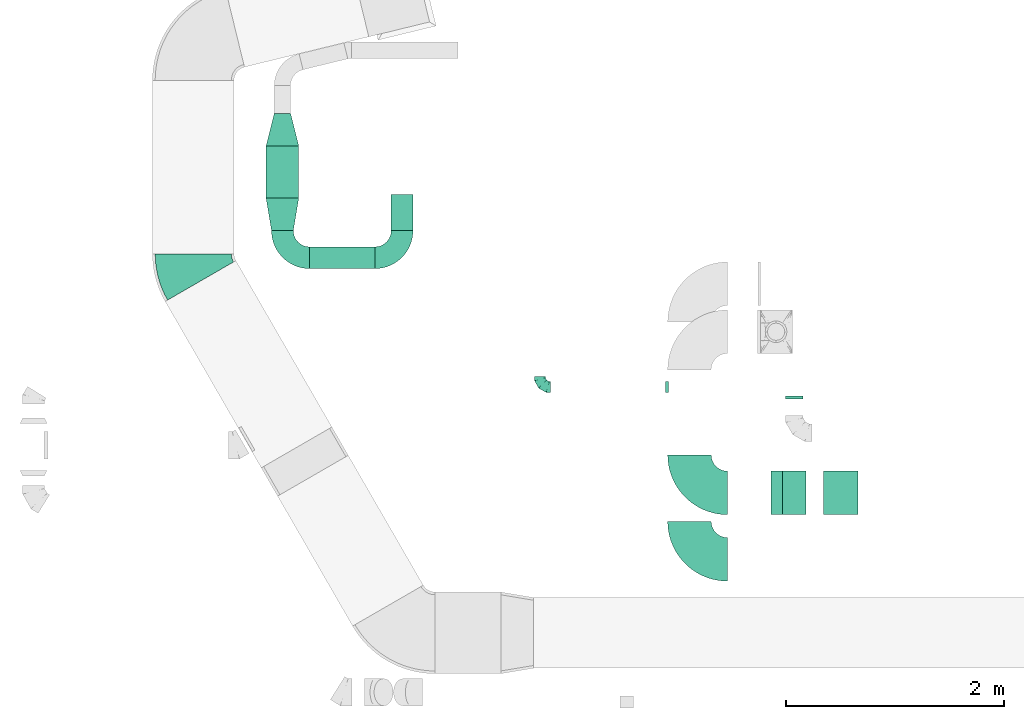
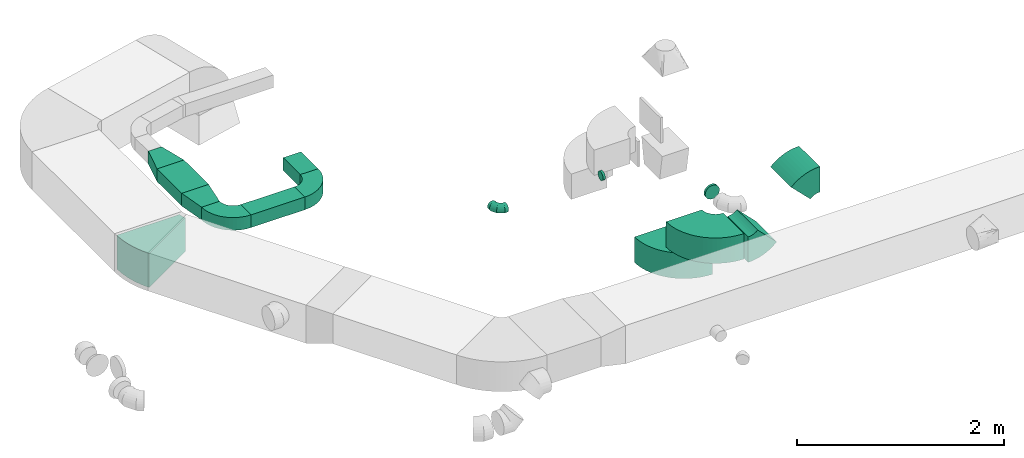
# One storey, part 5 of 44: 12 flow fittings, 3 flow segments.
"""IFC2X3 building model written with IfcOpenShell, lengths in millimetres."""

import ifcopenshell
import ifcopenshell.guid

model = None  # the IFC model being written
_history = None  # IfcOwnerHistory: only IFC2X3 demands one
_inside = {}  # id of a spatial element -> (the spatial element, [elements in it])
_under = {}  # id of a project, library or spatial element -> (it, [spatial elements below it])
_declared = {}  # id of a project -> (the project, [libraries it declares])
_typed = {}  # id of a type object -> (the type object, [elements of that type])
_made_of = {}  # id of a material, layer set ... -> (it, [elements and type objects made of it])


def new_model(schema):
    """Start an empty IFC model of exactly this schema.

    Asked for "IFC4X3", IfcOpenShell would pick the latest addendum, in which some entities
    have other attributes; the version numbers below select the first issue.
    IFC2X3 requires an IfcOwnerHistory on every rooted entity: one is made here for all.
    """
    global model, _history
    if schema == "IFC4X3":
        model = ifcopenshell.file(schema_version=(4, 3, 0, 0))
    else:
        model = ifcopenshell.file(schema=schema)
    _inside.clear()
    _under.clear()
    _declared.clear()
    _typed.clear()
    _made_of.clear()
    _history = None
    if model.schema == "IFC2X3":
        org = make("IfcOrganization", Name="unknown")
        user = make(
            "IfcPersonAndOrganization",
            ThePerson=make("IfcPerson", FamilyName="unknown"),
            TheOrganization=org,
        )
        app = make(
            "IfcApplication",
            ApplicationDeveloper=org,
            Version="unknown",
            ApplicationFullName="unknown",
            ApplicationIdentifier="unknown",
        )
        _history = make(
            "IfcOwnerHistory",
            OwningUser=user,
            OwningApplication=app,
            ChangeAction="ADDED",
            CreationDate=0,
        )
    return model


def make(cls, **values):
    """One entity of the class cls with the attributes given. An attribute that is None is left unset."""
    return model.create_entity(
        cls, **{name: value for name, value in values.items() if value is not None}
    )


def entity(cls, *values):
    """Any entity or typed value of the class cls, its attributes in the order of the schema. None: left unset."""
    e = model.create_entity(cls)
    for i, value in enumerate(values):
        if value is not None:
            e[i] = value
    return e


def rooted(cls, **values):
    """An entity with a GlobalId (a new one), such as an element, a storey or a relation."""
    return make(cls, GlobalId=ifcopenshell.guid.new(), OwnerHistory=_history, **values)


def si_unit(unit_type, name, prefix=None):
    """IfcSIUnit, for example si_unit("LENGTHUNIT", "METRE", prefix="MILLI")."""
    return make("IfcSIUnit", UnitType=unit_type, Prefix=prefix, Name=name)


def converted_unit(unit_type, name, factor, base, dimensions=None, offset=None):
    """IfcConversionBasedUnit, such as the inch: factor (a typed value) times the base unit."""
    return make(
        "IfcConversionBasedUnit"
        if offset is None
        else "IfcConversionBasedUnitWithOffset",
        ConversionOffset=offset,
        Dimensions=None
        if dimensions is None
        else entity("IfcDimensionalExponents", *dimensions),
        UnitType=unit_type,
        Name=name,
        ConversionFactor=make(
            "IfcMeasureWithUnit", ValueComponent=factor, UnitComponent=base
        ),
    )


def derived_unit(unit_type, elements):
    """IfcDerivedUnit: a product of units, each with its exponent."""
    return make(
        "IfcDerivedUnit",
        Elements=[
            make("IfcDerivedUnitElement", Unit=unit, Exponent=power)
            for unit, power in elements
        ],
        UnitType=unit_type,
    )


def assignment(units):
    """IfcUnitAssignment: the units of a project."""
    return None if units is None else make("IfcUnitAssignment", Units=units)


def point(xyz):
    """IfcCartesianPoint."""
    return None if xyz is None else make("IfcCartesianPoint", Coordinates=xyz)


def direction(xyz):
    """IfcDirection."""
    return None if xyz is None else make("IfcDirection", DirectionRatios=xyz)


def frame(location, z_axis=None, x_axis=None):
    """IfcAxis2Placement3D, a coordinate frame: its origin and axes. An axis left out is left unset."""
    return make(
        "IfcAxis2Placement3D",
        Location=point(location),
        Axis=direction(z_axis),
        RefDirection=direction(x_axis),
    )


def frame_2d(location, x_axis=None):
    """IfcAxis2Placement2D, a coordinate frame in the plane: its origin and x axis."""
    return make(
        "IfcAxis2Placement2D", Location=point(location), RefDirection=direction(x_axis)
    )


def origin():
    """The frame at (0, 0, 0) with its axes left unset."""
    return frame((0.0, 0.0, 0.0))


def origin_2d_with_axis():
    """The frame at (0, 0) in the plane with the x axis (1, 0) written out."""
    return frame_2d((0.0, 0.0), x_axis=(1.0, 0.0))


def place(relative_to, where):
    """IfcLocalPlacement: puts the frame where relative to a parent placement (None: the world)."""
    return make(
        "IfcLocalPlacement", PlacementRelTo=relative_to, RelativePlacement=where
    )


def context(
    kind, dimensions, precision=None, world=None, true_north=None, identifier=None
):
    """IfcGeometricRepresentationContext, for example the 3D "Model" context."""
    return make(
        "IfcGeometricRepresentationContext",
        ContextIdentifier=identifier,
        ContextType=kind,
        CoordinateSpaceDimension=dimensions,
        Precision=precision,
        WorldCoordinateSystem=world,
        TrueNorth=true_north,
    )


def subcontext(parent, identifier, kind, view, scale=None):
    """IfcGeometricRepresentationSubContext, for example "Body" below "Model"."""
    return make(
        "IfcGeometricRepresentationSubContext",
        ContextIdentifier=identifier,
        ContextType=kind,
        ParentContext=parent,
        TargetScale=scale,
        TargetView=view,
    )


def project(units=None, contexts=None):
    """IfcProject with its units and contexts."""
    return rooted(
        "IfcProject",
        Name="project",
        RepresentationContexts=contexts,
        UnitsInContext=assignment(units),
    )


def spatial(cls, under=None, at=None, **own):
    """A site, building, storey or space (cls), placed at a placement, below another one or the project."""
    s = rooted(cls, ObjectPlacement=at, **own)
    if under is not None:
        _under.setdefault(under.id(), (under, []))[1].append(s)
    return s


def polyline(points):
    """IfcPolyline through the points."""
    return make("IfcPolyline", Points=[point(p) for p in points])


def circle_curve(where, radius):
    """IfcCircle in the frame where."""
    return make("IfcCircle", Position=where, Radius=radius)


def parameter(value):
    """IfcParameterValue: where a trimmed curve begins or ends, as a parameter of its basis curve."""
    return model.create_entity("IfcParameterValue", value)


def trimmed(basis, trim1, trim2, sense, master):
    """IfcTrimmedCurve: the piece of a basis curve between two trims."""
    return make(
        "IfcTrimmedCurve",
        BasisCurve=basis,
        Trim1=trim1,
        Trim2=trim2,
        SenseAgreement=sense,
        MasterRepresentation=master,
    )


def segment(curve, same_sense, transition):
    """IfcCompositeCurveSegment."""
    return make(
        "IfcCompositeCurveSegment",
        Transition=transition,
        SameSense=same_sense,
        ParentCurve=curve,
    )


def composite_curve(segments, self_intersect=None):
    """IfcCompositeCurve: segments joined end to end."""
    return make("IfcCompositeCurve", Segments=segments, SelfIntersect=self_intersect)


def profile(cls, at=None, kind="AREA", **sizes):
    """A parametric profile (cls). Its sizes go by their IFC names, for example OverallWidth=200.0."""
    return make(cls, ProfileType=kind, Position=at, **sizes)


def rectangle(**sizes):
    """IfcRectangleProfileDef."""
    return profile("IfcRectangleProfileDef", **sizes)


def outline(outer, holes=None, kind="AREA"):
    """IfcArbitraryClosedProfileDef: a profile drawn as a closed curve; with holes, ...WithVoids."""
    if holes is None:
        return make("IfcArbitraryClosedProfileDef", ProfileType=kind, OuterCurve=outer)
    return make(
        "IfcArbitraryProfileDefWithVoids",
        ProfileType=kind,
        OuterCurve=outer,
        InnerCurves=holes,
    )


def extrude(swept, where, along, depth):
    """IfcExtrudedAreaSolid: the profile swept, set in the frame where, extruded along a direction by depth."""
    return make(
        "IfcExtrudedAreaSolid",
        SweptArea=swept,
        Position=where,
        ExtrudedDirection=direction(along),
        Depth=depth,
    )


def faces_of(points, faces, orient=None, outer=None):
    """IfcFace entities. A face is a list of loops; a loop is a list of indices into points, from 0.

    orient and outer hold one flag for each loop. By default every Orientation is true, the
    first loop of a face is its IfcFaceOuterBound and the others are IfcFaceBound.
    """
    made = []
    for i, loops in enumerate(faces):
        bounds = []
        for j, loop in enumerate(loops):
            is_outer = j == 0 if outer is None else outer[i][j]
            bounds.append(
                make(
                    "IfcFaceOuterBound" if is_outer else "IfcFaceBound",
                    Bound=make("IfcPolyLoop", Polygon=[points[k] for k in loop]),
                    Orientation=True if orient is None else orient[i][j],
                )
            )
        made.append(make("IfcFace", Bounds=bounds))
    return made


def faceted_brep(points, faces, orient=None, outer=None, voids=None):
    """IfcFacetedBrep: a solid bounded by flat faces; with voids (closed shells), ...WithVoids."""
    shared = [point(p) for p in points]
    hull = make("IfcClosedShell", CfsFaces=faces_of(shared, faces, orient, outer))
    if voids is None:
        return make("IfcFacetedBrep", Outer=hull)
    return make(
        "IfcFacetedBrepWithVoids",
        Outer=hull,
        Voids=[
            make(cls, CfsFaces=faces_of(shared, fs, o, b)) for cls, fs, o, b in voids
        ],
    )


def shape(context_of_items, identifier, shape_type, items):
    """IfcShapeRepresentation: the items that make up one representation, for example the "Body"."""
    return make(
        "IfcShapeRepresentation",
        ContextOfItems=context_of_items,
        RepresentationIdentifier=identifier,
        RepresentationType=shape_type,
        Items=items,
    )


def source(mapping_origin, context_of_items, identifier, shape_type, items):
    """IfcRepresentationMap: a shape defined once, which mapped items show again and again."""
    return make(
        "IfcRepresentationMap",
        MappingOrigin=mapping_origin,
        MappedRepresentation=shape(context_of_items, identifier, shape_type, items),
    )


def transform(
    local_origin,
    x_axis=None,
    y_axis=None,
    z_axis=None,
    scale=None,
    scale2=None,
    scale3=None,
    uniform=True,
):
    """IfcCartesianTransformationOperator3D, or its non-uniform kind. x_axis, y_axis, z_axis: its Axis1, 2, 3."""
    if uniform:
        return make(
            "IfcCartesianTransformationOperator3D",
            Axis1=direction(x_axis),
            Axis2=direction(y_axis),
            LocalOrigin=point(local_origin),
            Scale=scale,
            Axis3=direction(z_axis),
        )
    return make(
        "IfcCartesianTransformationOperator3DnonUniform",
        Axis1=direction(x_axis),
        Axis2=direction(y_axis),
        LocalOrigin=point(local_origin),
        Scale=scale,
        Axis3=direction(z_axis),
        Scale2=scale2,
        Scale3=scale3,
    )


def mapped(mapping_source, mapping_target):
    """IfcMappedItem: shows the shape of a source again, moved by a transform."""
    return make(
        "IfcMappedItem", MappingSource=mapping_source, MappingTarget=mapping_target
    )


def material(Name=None, Category=None):
    """IfcMaterial."""
    return make("IfcMaterial", Name=Name, Category=Category)


def made_of(thing, what):
    """Note that an element or type object is made of a material, layer set ...; save() writes the relation."""
    if what is not None:
        _made_of.setdefault(what.id(), (what, []))[1].append(thing)
    return thing


def type_object(cls, material=None, **own):
    """A type object (cls), such as IfcWallType, which elements share."""
    return made_of(rooted(cls, **own), material)


def type_shapes(of_type, sources):
    """Give a type object the sources (RepresentationMaps) that its elements show as mapped items."""
    of_type.RepresentationMaps = sources


def element(
    cls,
    number,
    at=None,
    inside=None,
    cuts=None,
    type_object=None,
    material=None,
    context=None,
    identifier="Body",
    shape_type=None,
    held_by="IfcProductDefinitionShape",
    body=None,
    shapes=None,
    **own,
):
    """One element of the class cls, such as IfcWall. Its Tag is "e" and its number.

    at: its placement. inside: the storey or other place that contains it. cuts: it is an
    opening in that element (IfcRelVoidsElement). A single representation is given by context,
    identifier, shape_type and body (its items); several are given by shapes. held_by: the class
    of the entity that holds the representations. save() writes the other relations.
    """
    e = rooted(cls, Tag="e%d" % number, ObjectPlacement=at, **own)
    if body is not None:
        shapes = [shape(context, identifier, shape_type, body)]
    if shapes is not None:
        e.Representation = make(held_by, Representations=shapes)
    if inside is not None:
        _inside.setdefault(inside.id(), (inside, []))[1].append(e)
    if cuts is not None:
        rooted(
            "IfcRelVoidsElement", RelatingBuildingElement=cuts, RelatedOpeningElement=e
        )
    if type_object is not None:
        _typed.setdefault(type_object.id(), (type_object, []))[1].append(e)
    return made_of(e, material)


def aggregate(whole, parts):
    """IfcRelAggregates: a whole, such as a stair, and the parts it consists of."""
    return rooted("IfcRelAggregates", RelatingObject=whole, RelatedObjects=parts)


def save(model, path):
    """Write the relations noted so far, then the file.

    IfcRelAggregates (storeys below a building ...), IfcRelContainedInSpatialStructure (elements
    in a storey), IfcRelDefinesByType, IfcRelAssociatesMaterial and IfcRelDeclares: one each for
    every whole, place, type object, material and project.
    """
    for whole, parts in _under.values():
        aggregate(whole, parts)
    for where, things in _inside.values():
        rooted(
            "IfcRelContainedInSpatialStructure",
            RelatedElements=things,
            RelatingStructure=where,
        )
    for kind, things in _typed.values():
        rooted("IfcRelDefinesByType", RelatedObjects=things, RelatingType=kind)
    for what, things in _made_of.values():
        rooted("IfcRelAssociatesMaterial", RelatedObjects=things, RelatingMaterial=what)
    for by, libraries in _declared.values():
        rooted("IfcRelDeclares", RelatingContext=by, RelatedDefinitions=libraries)
    model.write(path)


model = new_model("IFC2X3")

# Units and contexts
model_context = context("Model", 3, precision=0.01, world=origin(), true_north=direction((6.12303176911189e-17, 1.0)))
body_context = subcontext(model_context, "Body", "Model", "MODEL_VIEW")
ifc_project = project(units=[si_unit("LENGTHUNIT", "METRE", prefix="MILLI"), si_unit("AREAUNIT", "SQUARE_METRE"), si_unit("VOLUMEUNIT", "CUBIC_METRE"), converted_unit("PLANEANGLEUNIT", "DEGREE", entity("IfcRatioMeasure", 0.0174532925199433), si_unit("PLANEANGLEUNIT", "RADIAN"), dimensions=[0, 0, 0, 0, 0, 0, 0]), si_unit("MASSUNIT", "GRAM", prefix="KILO"), derived_unit("MASSDENSITYUNIT", [(si_unit("MASSUNIT", "GRAM", prefix="KILO"), 1), (si_unit("LENGTHUNIT", "METRE"), -3)]), derived_unit("MOMENTOFINERTIAUNIT", [(si_unit("LENGTHUNIT", "METRE"), 4)]), si_unit("TIMEUNIT", "SECOND"), si_unit("FREQUENCYUNIT", "HERTZ"), si_unit("THERMODYNAMICTEMPERATUREUNIT", "DEGREE_CELSIUS"), derived_unit("THERMALTRANSMITTANCEUNIT", [(si_unit("MASSUNIT", "GRAM", prefix="KILO"), 1), (si_unit("THERMODYNAMICTEMPERATUREUNIT", "KELVIN"), -1), (si_unit("TIMEUNIT", "SECOND"), -3)]), derived_unit("VOLUMETRICFLOWRATEUNIT", [(si_unit("LENGTHUNIT", "METRE"), 3), (si_unit("TIMEUNIT", "SECOND"), -1)]), derived_unit("MASSFLOWRATEUNIT", [(si_unit("MASSUNIT", "GRAM", prefix="KILO"), 1), (si_unit("TIMEUNIT", "SECOND"), -1)]), derived_unit("ROTATIONALFREQUENCYUNIT", [(si_unit("TIMEUNIT", "SECOND"), -1)]), si_unit("ELECTRICCURRENTUNIT", "AMPERE"), si_unit("ELECTRICVOLTAGEUNIT", "VOLT"), si_unit("POWERUNIT", "WATT"), si_unit("FORCEUNIT", "NEWTON", prefix="KILO"), si_unit("ILLUMINANCEUNIT", "LUX"), si_unit("LUMINOUSFLUXUNIT", "LUMEN"), si_unit("LUMINOUSINTENSITYUNIT", "CANDELA"), derived_unit("USERDEFINED", [(si_unit("MASSUNIT", "GRAM", prefix="KILO"), -1), (si_unit("LENGTHUNIT", "METRE"), -2), (si_unit("TIMEUNIT", "SECOND"), 3), (si_unit("LUMINOUSFLUXUNIT", "LUMEN"), 1)]), derived_unit("LINEARVELOCITYUNIT", [(si_unit("LENGTHUNIT", "METRE"), 1), (si_unit("TIMEUNIT", "SECOND"), -1)]), si_unit("PRESSUREUNIT", "PASCAL"), derived_unit("USERDEFINED", [(si_unit("LENGTHUNIT", "METRE"), -2), (si_unit("MASSUNIT", "GRAM", prefix="KILO"), 1), (si_unit("TIMEUNIT", "SECOND"), -2)]), derived_unit("LINEARFORCEUNIT", [(si_unit("MASSUNIT", "GRAM", prefix="KILO"), 1), (si_unit("LENGTHUNIT", "METRE"), 1), (si_unit("TIMEUNIT", "SECOND"), -2), (si_unit("LENGTHUNIT", "METRE"), -1)]), derived_unit("PLANARFORCEUNIT", [(si_unit("MASSUNIT", "GRAM", prefix="KILO"), 1), (si_unit("LENGTHUNIT", "METRE"), 1), (si_unit("TIMEUNIT", "SECOND"), -2), (si_unit("LENGTHUNIT", "METRE"), -2)])], contexts=[model_context])

# Site, building, storey
site_placement = place(None, origin())
site = spatial("IfcSite", under=ifc_project, at=site_placement, CompositionType="ELEMENT")
building_placement = place(site_placement, origin())
building = spatial("IfcBuilding", under=site, at=building_placement, CompositionType="ELEMENT")
storey_placement = place(building_placement, frame((0.0, 0.0, 15900.0)))
storey = spatial("IfcBuildingStorey", under=building, at=storey_placement, CompositionType="ELEMENT", Elevation=15900.0)

# Flow segments
duct_segment_type = type_object("IfcDuctSegmentType", PredefinedType="NOTDEFINED")
flow_segment_1_placement = place(storey_placement, frame((3334.58, 15589.19, 3125.0)))
element("IfcFlowSegment", 1, at=flow_segment_1_placement, inside=storey, type_object=duct_segment_type, context=body_context, shape_type="SweptSolid", body=[
    extrude(rectangle(XDim=475.672304103139, YDim=300.0, at=origin_2d_with_axis()), frame((150.0, 237.84, 0.0), z_axis=(0.0, 0.0, 1.0), x_axis=(0.0, -1.0, 0.0)), (0.0, 0.0, 1.0), 150.000000000001),
])
flow_segment_2_placement = place(storey_placement, frame((3734.58, 14939.19, 3125.0)))
element("IfcFlowSegment", 2, at=flow_segment_2_placement, inside=storey, type_object=duct_segment_type, context=body_context, shape_type="SweptSolid", body=[
    extrude(rectangle(XDim=600.000000000015, YDim=200.0, at=origin_2d_with_axis()), frame((300.0, 100.0, 0.0)), (0.0, 0.0, 1.0), 150.000000000001),
])
flow_segment_3_placement = place(storey_placement, frame((4484.58, 15289.19, 3125.0)))
element("IfcFlowSegment", 3, at=flow_segment_3_placement, inside=storey, type_object=duct_segment_type, context=body_context, shape_type="SweptSolid", body=[
    extrude(rectangle(XDim=330.000000000009, YDim=200.0, at=origin_2d_with_axis()), frame((100.0, 165.0, 0.0), z_axis=(0.0, 0.0, 1.0), x_axis=(0.0, 1.0, 0.0)), (0.0, 0.0, 1.0), 150.000000000001),
])

# Flow fittings
ifc_material = material()
duct_fitting_type_1 = type_object("IfcDuctFittingType", PredefinedType="NOTDEFINED", material=ifc_material)
shared_shape_1 = source(origin(), body_context, "Body", "SweptSolid", [
    extrude(outline(polyline([(-127.33, -109.14), (181.9, -109.14), (109.14, 181.9), (-163.71, 36.38), (-127.33, -109.14)])), frame((150.0, 0.0, -75.0), z_axis=(0.0, 0.0, 1.0), x_axis=(0.970142500145332, -0.242535625036335, 0.0)), (0.0, 0.0, 1.0), 150.0),
])
type_shapes(duct_fitting_type_1, [shared_shape_1])
flow_fitting_1_placement = place(storey_placement, frame((3484.58, 16364.86, 3200.0), z_axis=(0.0, 0.0, 1.0), x_axis=(0.0, -1.0, 0.0)))
element("IfcFlowFitting", 4, at=flow_fitting_1_placement, inside=storey, type_object=duct_fitting_type_1, material=ifc_material, context=body_context, shape_type="MappedRepresentation", body=[
    mapped(shared_shape_1, transform((0.0, 0.0, 0.0), scale=1.0)),
])
duct_fitting_type_2 = type_object("IfcDuctFittingType", PredefinedType="NOTDEFINED", material=ifc_material)
shared_shape_2 = source(origin(), body_context, "Body", "SweptSolid", [
    extrude(outline(polyline([(-131.52, -123.3), (172.62, -123.3), (123.3, 172.62), (-164.4, 73.98), (-131.52, -123.3)])), frame((150.0, 0.0, -75.0), z_axis=(0.0, 0.0, 1.0), x_axis=(0.986393923832143, -0.164398987305359, 0.0)), (0.0, 0.0, 1.0), 150.0),
])
type_shapes(duct_fitting_type_2, [shared_shape_2])
flow_fitting_2_placement = place(storey_placement, frame((3484.58, 15289.19, 3200.0), z_axis=(0.0, 0.0, 1.0), x_axis=(0.0, 1.0, 0.0)))
element("IfcFlowFitting", 5, at=flow_fitting_2_placement, inside=storey, type_object=duct_fitting_type_2, material=ifc_material, context=body_context, shape_type="MappedRepresentation", body=[
    mapped(shared_shape_2, transform((0.0, 0.0, 0.0), scale=1.0)),
])
duct_fitting_type_3 = type_object("IfcDuctFittingType", PredefinedType="NOTDEFINED", material=ifc_material)
shared_shape_3 = source(origin(), body_context, "Body", "Brep", [
    faceted_brep([(-100.0, 0.0, -50.0), (-100.0, -12.94, -48.3), (-100.0, -25.0, -43.3), (-100.0, -35.36, -35.36), (-100.0, -43.3, -25.0), (-100.0, -48.3, -12.94), (-100.0, -50.0, 0.0), (-100.0, -48.3, 12.94), (-100.0, -43.3, 25.0), (-100.0, -35.36, 35.36), (-100.0, -25.0, 43.3), (-100.0, -12.94, 48.3), (-100.0, 0.0, 50.0), (-100.0, 12.94, 48.3), (-100.0, 25.0, 43.3), (-100.0, 35.36, 35.36), (-100.0, 43.3, 25.0), (-100.0, 48.3, 12.94), (-100.0, 50.0, 0.0), (-100.0, 48.3, -12.94), (-100.0, 43.3, -25.0), (-100.0, 35.36, -35.36), (-100.0, 25.0, -43.3), (-100.0, 12.94, -48.3), (-76.67, 12.94, 48.3), (-79.9, 25.0, 43.3), (-73.21, 0.0, 50.0), (-82.68, 35.36, 35.36), (-86.15, 48.3, 12.94), (-86.6, 50.0, 0.0), (-84.81, 43.3, 25.0), (-84.81, 43.3, -25.0), (-82.68, 35.36, -35.36), (-86.15, 48.3, -12.94), (-76.67, 12.94, -48.3), (-73.21, 0.0, -50.0), (-79.9, 25.0, -43.3), (-69.74, -12.94, -48.3), (-66.51, -25.0, -43.3), (-63.73, -35.36, -35.36), (-61.6, -43.3, -25.0), (-60.26, -48.3, -12.94), (-59.81, -50.0, 0.0), (-60.26, -48.3, 12.94), (-61.6, -43.3, 25.0), (-63.73, -35.36, 35.36), (-66.51, -25.0, 43.3), (-69.74, -12.94, 48.3), (-36.27, 36.27, 48.3), (-45.1, 45.1, 43.3), (-26.79, 26.79, 50.0), (-52.68, 52.68, 35.36), (-58.49, 58.49, 25.0), (-62.15, 62.15, 12.94), (-63.4, 63.4, 0.0), (-62.15, 62.15, -12.94), (-58.49, 58.49, -25.0), (-52.68, 52.68, -35.36), (-36.27, 36.27, -48.3), (-26.79, 26.79, -50.0), (-45.1, 45.1, -43.3), (-17.32, 17.32, -48.3), (-8.49, 8.49, -43.3), (-0.91, 0.91, -35.36), (4.9, -4.9, -25.0), (8.56, -8.56, -12.94), (9.81, -9.81, 0.0), (8.56, -8.56, 12.94), (4.9, -4.9, 25.0), (-0.91, 0.91, 35.36), (-8.49, 8.49, 43.3), (-17.32, 17.32, 48.3), (-12.94, 76.67, 48.3), (-25.0, 79.9, 43.3), (0.0, 73.21, 50.0), (-35.36, 82.68, 35.36), (-43.3, 84.81, 25.0), (-48.3, 86.15, 12.94), (-50.0, 86.6, 0.0), (-48.3, 86.15, -12.94), (-43.3, 84.81, -25.0), (-35.36, 82.68, -35.36), (-12.94, 76.67, -48.3), (0.0, 73.21, -50.0), (-25.0, 79.9, -43.3), (12.94, 69.74, -48.3), (25.0, 66.51, -43.3), (35.36, 63.73, -35.36), (43.3, 61.6, -25.0), (48.3, 60.26, -12.94), (50.0, 59.81, 0.0), (48.3, 60.26, 12.94), (43.3, 61.6, 25.0), (35.36, 63.73, 35.36), (25.0, 66.51, 43.3), (12.94, 69.74, 48.3), (-12.94, 100.0, -48.3), (-25.0, 100.0, -43.3), (-35.36, 100.0, -35.36), (-43.3, 100.0, -25.0), (-48.3, 100.0, -12.94), (-50.0, 100.0, 0.0), (-48.3, 100.0, 12.94), (-43.3, 100.0, 25.0), (-35.36, 100.0, 35.36), (-25.0, 100.0, 43.3), (-12.94, 100.0, 48.3), (0.0, 100.0, 50.0), (12.94, 100.0, 48.3), (25.0, 100.0, 43.3), (35.36, 100.0, 35.36), (43.3, 100.0, 25.0), (48.3, 100.0, 12.94), (50.0, 100.0, 0.0), (48.3, 100.0, -12.94), (43.3, 100.0, -25.0), (35.36, 100.0, -35.36), (25.0, 100.0, -43.3), (12.94, 100.0, -48.3), (0.0, 100.0, -50.0)], [[[0, 1, 2, 3, 4, 5, 6, 7, 8, 9, 10, 11, 12, 13, 14, 15, 16, 17, 18, 19, 20, 21, 22, 23]], [[24, 25, 14, 13]], [[26, 24, 13, 12]], [[14, 25, 27, 15]], [[28, 29, 18, 17]], [[30, 28, 17, 16]], [[15, 27, 30, 16]], [[20, 31, 32, 21]], [[33, 31, 20, 19]], [[18, 29, 33, 19]], [[34, 35, 0, 23]], [[36, 34, 23, 22]], [[32, 36, 22, 21]], [[2, 1, 37, 38]], [[3, 2, 38, 39]], [[0, 35, 37, 1]], [[5, 4, 40, 41]], [[6, 5, 41, 42]], [[3, 39, 40, 4]], [[6, 42, 43, 7]], [[7, 43, 44, 8]], [[8, 44, 45, 9]], [[10, 46, 47, 11]], [[11, 47, 26, 12]], [[10, 9, 45, 46]], [[48, 49, 25, 24]], [[50, 48, 24, 26]], [[27, 25, 49, 51]], [[52, 53, 28, 30]], [[51, 52, 30, 27]], [[29, 28, 53, 54]], [[55, 56, 31, 33]], [[54, 55, 33, 29]], [[57, 32, 31, 56]], [[58, 59, 35, 34]], [[60, 58, 34, 36]], [[57, 60, 36, 32]], [[37, 35, 59, 61]], [[38, 37, 61, 62]], [[39, 38, 62, 63]], [[41, 40, 64, 65]], [[42, 41, 65, 66]], [[63, 64, 40, 39]], [[43, 42, 66, 67]], [[44, 43, 67, 68]], [[68, 69, 45, 44]], [[46, 45, 69, 70]], [[47, 46, 70, 71]], [[26, 47, 71, 50]], [[72, 73, 49, 48]], [[74, 72, 48, 50]], [[51, 49, 73, 75]], [[76, 77, 53, 52]], [[75, 76, 52, 51]], [[54, 53, 77, 78]], [[79, 80, 56, 55]], [[78, 79, 55, 54]], [[81, 57, 56, 80]], [[82, 83, 59, 58]], [[84, 82, 58, 60]], [[81, 84, 60, 57]], [[61, 59, 83, 85]], [[62, 61, 85, 86]], [[63, 62, 86, 87]], [[65, 64, 88, 89]], [[66, 65, 89, 90]], [[87, 88, 64, 63]], [[67, 66, 90, 91]], [[68, 67, 91, 92]], [[92, 93, 69, 68]], [[70, 69, 93, 94]], [[71, 70, 94, 95]], [[50, 71, 95, 74]], [[96, 97, 98, 99, 100, 101, 102, 103, 104, 105, 106, 107, 108, 109, 110, 111, 112, 113, 114, 115, 116, 117, 118, 119]], [[72, 74, 107, 106]], [[73, 72, 106, 105]], [[75, 73, 105, 104]], [[77, 76, 103, 102]], [[78, 77, 102, 101]], [[75, 104, 103, 76]], [[78, 101, 100, 79]], [[79, 100, 99, 80]], [[80, 99, 98, 81]], [[96, 119, 83, 82]], [[97, 96, 82, 84]], [[84, 81, 98, 97]], [[83, 119, 118, 85]], [[85, 118, 117, 86]], [[86, 117, 116, 87]], [[88, 115, 114, 89]], [[89, 114, 113, 90]], [[87, 116, 115, 88]], [[91, 90, 113, 112]], [[92, 91, 112, 111]], [[93, 92, 111, 110]], [[95, 94, 109, 108]], [[74, 95, 108, 107]], [[110, 109, 94, 93]]]),
])
type_shapes(duct_fitting_type_3, [shared_shape_3])
flow_fitting_3_placement = place(storey_placement, frame((5850.44, 13850.35, 3250.0), z_axis=(0.0, 0.0, 1.0), x_axis=(0.0, -1.0, 0.0)))
element("IfcFlowFitting", 6, at=flow_fitting_3_placement, inside=storey, type_object=duct_fitting_type_3, material=ifc_material, context=body_context, shape_type="MappedRepresentation", body=[
    mapped(shared_shape_3, transform((0.0, 0.0, 0.0), scale=1.0)),
])
duct_fitting_type_4 = type_object("IfcDuctFittingType", PredefinedType="NOTDEFINED", material=ifc_material)
shared_shape_4 = source(origin(), body_context, "Body", "Brep", [
    faceted_brep([(20.0, 20.71, -77.27), (20.0, 40.0, -69.28), (20.0, 56.57, -56.57), (20.0, 69.28, -40.0), (20.0, 77.27, -20.71), (20.0, 80.0, 0.0), (20.0, 77.27, 20.71), (20.0, 69.28, 40.0), (20.0, 56.57, 56.57), (20.0, 40.0, 69.28), (20.0, 20.71, 77.27), (20.0, 0.0, 80.0), (20.0, -20.71, 77.27), (20.0, -40.0, 69.28), (20.0, -56.57, 56.57), (20.0, -69.28, 40.0), (20.0, -77.27, 20.71), (20.0, -80.0, 0.0), (20.0, -77.27, -20.71), (20.0, -69.28, -40.0), (20.0, -56.57, -56.57), (20.0, -40.0, -69.28), (20.0, -20.71, -77.27), (20.0, 0.0, -80.0), (0.0, 0.0, 80.0), (0.0, 20.71, 77.27), (-6.1, 20.71, 77.27), (-6.1, 0.0, 80.0), (0.0, 40.0, 69.28), (-6.1, 40.0, 69.28), (0.0, 56.57, 56.57), (-6.1, 56.57, 56.57), (0.0, 69.28, 40.0), (0.0, 77.27, 20.71), (-6.1, 77.27, 20.71), (-6.1, 69.28, 40.0), (0.0, 80.0, 0.0), (-6.1, 80.0, 0.0), (0.0, 77.27, -20.71), (-6.1, 77.27, -20.71), (0.0, 69.28, -40.0), (-6.1, 69.28, -40.0), (0.0, 56.57, -56.57), (-6.1, 56.57, -56.57), (0.0, 40.0, -69.28), (0.0, 20.71, -77.27), (-6.1, 20.71, -77.27), (-6.1, 40.0, -69.28), (0.0, 0.0, -80.0), (-6.1, 0.0, -80.0), (0.0, -20.71, -77.27), (-6.1, -20.71, -77.27), (0.0, -40.0, -69.28), (-6.1, -40.0, -69.28), (0.0, -56.57, -56.57), (-6.1, -56.57, -56.57), (0.0, -69.28, -40.0), (0.0, -77.27, -20.71), (-6.1, -77.27, -20.71), (-6.1, -69.28, -40.0), (0.0, -80.0, 0.0), (-6.1, -80.0, 0.0), (0.0, -77.27, 20.71), (-6.1, -77.27, 20.71), (0.0, -69.28, 40.0), (-6.1, -69.28, 40.0), (0.0, -56.57, 56.57), (-6.1, -56.57, 56.57), (0.0, -40.0, 69.28), (0.0, -20.71, 77.27), (-6.1, -20.71, 77.27), (-6.1, -40.0, 69.28)], [[[0, 1, 2, 3, 4, 5, 6, 7, 8, 9, 10, 11, 12, 13, 14, 15, 16, 17, 18, 19, 20, 21, 22, 23]], [[24, 11, 10, 25, 26, 27]], [[25, 10, 9, 28, 29, 26]], [[28, 9, 8, 30, 31, 29]], [[32, 7, 6, 33, 34, 35]], [[33, 6, 5, 36, 37, 34]], [[30, 8, 7, 32, 35, 31]], [[36, 5, 4, 38, 39, 37]], [[38, 4, 3, 40, 41, 39]], [[40, 3, 2, 42, 43, 41]], [[44, 1, 0, 45, 46, 47]], [[45, 0, 23, 48, 49, 46]], [[42, 2, 1, 44, 47, 43]], [[48, 23, 22, 50, 51, 49]], [[50, 22, 21, 52, 53, 51]], [[52, 21, 20, 54, 55, 53]], [[56, 19, 18, 57, 58, 59]], [[57, 18, 17, 60, 61, 58]], [[54, 20, 19, 56, 59, 55]], [[60, 17, 16, 62, 63, 61]], [[62, 16, 15, 64, 65, 63]], [[64, 15, 14, 66, 67, 65]], [[68, 13, 12, 69, 70, 71]], [[69, 12, 11, 24, 27, 70]], [[66, 14, 13, 68, 71, 67]], [[49, 51, 53, 55, 59, 58, 61, 63, 65, 67, 71, 70, 27, 26, 29, 31, 35, 34, 37, 39, 41, 43, 47, 46]]]),
])
type_shapes(duct_fitting_type_4, [shared_shape_4])
flow_fitting_4_placement = place(storey_placement, frame((8189.69, 13760.69, 2710.0), z_axis=(-1.0, 0.0, 0.0), x_axis=(0.0, -1.0, 0.0)))
element("IfcFlowFitting", 7, at=flow_fitting_4_placement, inside=storey, type_object=duct_fitting_type_4, material=ifc_material, context=body_context, shape_type="MappedRepresentation", body=[
    mapped(shared_shape_4, transform((0.0, 0.0, 0.0), scale=1.0)),
])
duct_fitting_type_5 = type_object("IfcDuctFittingType", PredefinedType="NOTDEFINED", material=ifc_material)
shared_shape_5 = source(origin(), body_context, "Body", "Brep", [
    faceted_brep([(20.0, 12.94, -48.3), (20.0, 25.0, -43.3), (20.0, 35.36, -35.36), (20.0, 43.3, -25.0), (20.0, 48.3, -12.94), (20.0, 50.0, 0.0), (20.0, 48.3, 12.94), (20.0, 43.3, 25.0), (20.0, 35.36, 35.36), (20.0, 25.0, 43.3), (20.0, 12.94, 48.3), (20.0, 0.0, 50.0), (20.0, -12.94, 48.3), (20.0, -25.0, 43.3), (20.0, -35.36, 35.36), (20.0, -43.3, 25.0), (20.0, -48.3, 12.94), (20.0, -50.0, 0.0), (20.0, -48.3, -12.94), (20.0, -43.3, -25.0), (20.0, -35.36, -35.36), (20.0, -25.0, -43.3), (20.0, -12.94, -48.3), (20.0, 0.0, -50.0), (0.0, 0.0, 50.0), (0.0, 12.94, 48.3), (-6.1, 12.94, 48.3), (-6.1, 0.0, 50.0), (0.0, 25.0, 43.3), (-6.1, 25.0, 43.3), (0.0, 35.36, 35.36), (-6.1, 35.36, 35.36), (0.0, 43.3, 25.0), (0.0, 48.3, 12.94), (-6.1, 48.3, 12.94), (-6.1, 43.3, 25.0), (0.0, 50.0, 0.0), (-6.1, 50.0, 0.0), (0.0, 48.3, -12.94), (-6.1, 48.3, -12.94), (0.0, 43.3, -25.0), (-6.1, 43.3, -25.0), (0.0, 35.36, -35.36), (-6.1, 35.36, -35.36), (0.0, 25.0, -43.3), (0.0, 12.94, -48.3), (-6.1, 12.94, -48.3), (-6.1, 25.0, -43.3), (0.0, 0.0, -50.0), (-6.1, 0.0, -50.0), (0.0, -12.94, -48.3), (-6.1, -12.94, -48.3), (0.0, -25.0, -43.3), (-6.1, -25.0, -43.3), (0.0, -35.36, -35.36), (-6.1, -35.36, -35.36), (0.0, -43.3, -25.0), (0.0, -48.3, -12.94), (-6.1, -48.3, -12.94), (-6.1, -43.3, -25.0), (0.0, -50.0, 0.0), (-6.1, -50.0, 0.0), (0.0, -48.3, 12.94), (-6.1, -48.3, 12.94), (0.0, -43.3, 25.0), (-6.1, -43.3, 25.0), (0.0, -35.36, 35.36), (-6.1, -35.36, 35.36), (0.0, -25.0, 43.3), (0.0, -12.94, 48.3), (-6.1, -12.94, 48.3), (-6.1, -25.0, 43.3)], [[[0, 1, 2, 3, 4, 5, 6, 7, 8, 9, 10, 11, 12, 13, 14, 15, 16, 17, 18, 19, 20, 21, 22, 23]], [[24, 11, 10, 25, 26, 27]], [[25, 10, 9, 28, 29, 26]], [[28, 9, 8, 30, 31, 29]], [[32, 7, 6, 33, 34, 35]], [[33, 6, 5, 36, 37, 34]], [[30, 8, 7, 32, 35, 31]], [[36, 5, 4, 38, 39, 37]], [[38, 4, 3, 40, 41, 39]], [[40, 3, 2, 42, 43, 41]], [[44, 1, 0, 45, 46, 47]], [[45, 0, 23, 48, 49, 46]], [[42, 2, 1, 44, 47, 43]], [[48, 23, 22, 50, 51, 49]], [[50, 22, 21, 52, 53, 51]], [[52, 21, 20, 54, 55, 53]], [[56, 19, 18, 57, 58, 59]], [[57, 18, 17, 60, 61, 58]], [[54, 20, 19, 56, 59, 55]], [[60, 17, 16, 62, 63, 61]], [[62, 16, 15, 64, 65, 63]], [[64, 15, 14, 66, 67, 65]], [[68, 13, 12, 69, 70, 71]], [[69, 12, 11, 24, 27, 70]], [[66, 14, 13, 68, 71, 67]], [[49, 51, 53, 55, 59, 58, 61, 63, 65, 67, 71, 70, 27, 26, 29, 31, 35, 34, 37, 39, 41, 43, 47, 46]]]),
])
type_shapes(duct_fitting_type_5, [shared_shape_5])
flow_fitting_5_placement = place(storey_placement, frame((7024.85, 13850.35, 3250.0), z_axis=(0.0, 0.0, -1.0), x_axis=(-1.0, 0.0, 0.0)))
element("IfcFlowFitting", 8, at=flow_fitting_5_placement, inside=storey, type_object=duct_fitting_type_5, material=ifc_material, context=body_context, shape_type="MappedRepresentation", body=[
    mapped(shared_shape_5, transform((0.0, 0.0, 0.0), scale=1.0)),
])
duct_fitting_type_6 = type_object("IfcDuctFittingType", PredefinedType="NOTDEFINED", material=ifc_material)
shared_shape_6 = source(origin(), body_context, "Body", "SweptSolid", [
    extrude(outline(composite_curve([segment(polyline([(-375.0, -175.0), (25.0, -175.0)]), True, "CONTINUOUS"), segment(trimmed(circle_curve(frame_2d((175.0, -175.0), x_axis=(0.0, 1.0)), 150.0), [parameter(0.0)], [parameter(90.0000000000001)], True, "PARAMETER"), False, "CONTINUOUS"), segment(polyline([(175.0, -25.0), (175.0, 375.0)]), True, "CONTINUOUS"), segment(trimmed(circle_curve(frame_2d((175.0, -175.0), x_axis=(0.0, 1.0)), 550.0), [parameter(0.0)], [parameter(90.0)], True, "PARAMETER"), True, "CONTINUOUS")], self_intersect=False)), frame((-175.0, 175.0, -150.0), z_axis=(0.0, 0.0, 1.0), x_axis=(-1.0, 0.0, 0.0)), (0.0, 0.0, 1.0), 300.0),
])
type_shapes(duct_fitting_type_6, [shared_shape_6])
for number, where, z_axis, x_axis in (
    (9, (7224.85, 12267.41, 3300.0), (0.0, 0.0, 1.0), (0.0, -1.0, 0.0)),
    (10, (7225.26, 12878.06, 2750.0), (0.0, 0.0, 1.0), (0.0, -1.0, 0.0)),
):
    element("IfcFlowFitting", number, at=place(storey_placement, frame(where, z_axis=z_axis, x_axis=x_axis)), inside=storey, type_object=duct_fitting_type_6, material=ifc_material, context=body_context, shape_type="MappedRepresentation", body=[
        mapped(shared_shape_6, transform((0.0, 0.0, 0.0), scale=1.0)),
    ])
duct_fitting_type_7 = type_object("IfcDuctFittingType", PredefinedType="NOTDEFINED", material=ifc_material)
shared_shape_7 = source(origin(), body_context, "Body", "SweptSolid", [
    extrude(outline(composite_curve([segment(polyline([(-383.49, -125.0), (316.51, -125.0)]), True, "CONTINUOUS"), segment(trimmed(circle_curve(frame_2d((466.51, -125.0), x_axis=(-0.866025403784441, 0.499999999999996)), 150.0), [parameter(0.0)], [parameter(29.9999999999999)], True, "PARAMETER"), False, "CONTINUOUS"), segment(polyline([(336.6, -50.0), (-269.62, 300.0)]), True, "CONTINUOUS"), segment(trimmed(circle_curve(frame_2d((466.51, -125.0), x_axis=(-0.866025403784441, 0.499999999999996)), 850.0), [parameter(0.0)], [parameter(29.9999999999999)], True, "PARAMETER"), True, "CONTINUOUS")], self_intersect=False)), frame((-8.97, 33.49, -200.0), z_axis=(0.0, 0.0, 1.0), x_axis=(-0.499999999999998, 0.86602540378444, 0.0)), (0.0, 0.0, 1.0), 400.0),
])
type_shapes(duct_fitting_type_7, [shared_shape_7])
flow_fitting_6_placement = place(storey_placement, frame((2665.23, 14941.11, 3250.0), z_axis=(0.0, 0.0, 1.0), x_axis=(0.0, -1.0, 0.0)))
element("IfcFlowFitting", 11, at=flow_fitting_6_placement, inside=storey, type_object=duct_fitting_type_7, material=ifc_material, context=body_context, shape_type="MappedRepresentation", body=[
    mapped(shared_shape_7, transform((0.0, 0.0, 0.0), scale=1.0)),
])
duct_fitting_type_8 = type_object("IfcDuctFittingType", PredefinedType="NOTDEFINED", material=ifc_material)
shared_shape_8 = source(origin(), body_context, "Body", "SweptSolid", [
    extrude(outline(composite_curve([segment(polyline([(-193.93, -106.07), (106.07, -106.07)]), True, "CONTINUOUS"), segment(trimmed(circle_curve(frame_2d((256.07, -106.07), x_axis=(-0.707106781186553, 0.707106781186553)), 150.0), [parameter(0.0)], [parameter(45.0)], True, "PARAMETER"), False, "CONTINUOUS"), segment(polyline([(150.0, 0.0), (-62.13, 212.13)]), True, "CONTINUOUS"), segment(trimmed(circle_curve(frame_2d((256.07, -106.07), x_axis=(-0.707106781186553, 0.707106781186553)), 450.0), [parameter(0.0)], [parameter(45.0)], True, "PARAMETER"), True, "CONTINUOUS")], self_intersect=False)), frame((-18.2, 43.93, -200.0), z_axis=(0.0, 0.0, 1.0), x_axis=(-0.707106781186547, 0.707106781186548, 0.0)), (0.0, 0.0, 1.0), 400.0),
])
type_shapes(duct_fitting_type_8, [shared_shape_8])
for number, where, z_axis, x_axis in (
    (12, (8650.26, 12878.06, 3300.0), (0.0, -1.0, 0.0), (-1.0, 0.0, 0.0)),
    (13, (8100.26, 12878.06, 2750.0), (0.0, 1.0, 0.0), (-0.70710678118651, 0.0, -0.707106781186585)),
):
    element("IfcFlowFitting", number, at=place(storey_placement, frame(where, z_axis=z_axis, x_axis=x_axis)), inside=storey, type_object=duct_fitting_type_8, material=ifc_material, context=body_context, shape_type="MappedRepresentation", body=[
        mapped(shared_shape_8, transform((0.0, 0.0, 0.0), scale=1.0)),
    ])
duct_fitting_type_9 = type_object("IfcDuctFittingType", PredefinedType="NOTDEFINED", material=ifc_material)
shared_shape_9 = source(origin(), body_context, "Body", "SweptSolid", [
    extrude(outline(composite_curve([segment(polyline([(-225.0, -125.0), (-25.0, -125.0)]), True, "CONTINUOUS"), segment(trimmed(circle_curve(frame_2d((125.0, -125.0), x_axis=(0.0, 1.0)), 150.0), [parameter(0.0)], [parameter(90.0000000000001)], True, "PARAMETER"), False, "CONTINUOUS"), segment(polyline([(125.0, 25.0), (125.0, 225.0)]), True, "CONTINUOUS"), segment(trimmed(circle_curve(frame_2d((125.0, -125.0), x_axis=(0.0, 1.0)), 350.0), [parameter(0.0)], [parameter(90.0000000000001)], True, "PARAMETER"), True, "CONTINUOUS")], self_intersect=False)), frame((-125.0, 125.0, -75.0), z_axis=(0.0, 0.0, 1.0), x_axis=(-1.0, 0.0, 0.0)), (0.0, 0.0, 1.0), 150.0),
])
type_shapes(duct_fitting_type_9, [shared_shape_9])
flow_fitting_7_placement = place(storey_placement, frame((3484.58, 15039.19, 3200.0), z_axis=(0.0, 0.0, 1.0), x_axis=(0.0, -1.0, 0.0)))
element("IfcFlowFitting", 14, at=flow_fitting_7_placement, inside=storey, type_object=duct_fitting_type_9, material=ifc_material, context=body_context, shape_type="MappedRepresentation", body=[
    mapped(shared_shape_9, transform((0.0, 0.0, 0.0), scale=1.0)),
])
flow_fitting_8_placement = place(storey_placement, frame((4584.58, 15039.19, 3200.0)))
element("IfcFlowFitting", 15, at=flow_fitting_8_placement, inside=storey, type_object=duct_fitting_type_9, material=ifc_material, context=body_context, shape_type="MappedRepresentation", body=[
    mapped(shared_shape_9, transform((0.0, 0.0, 0.0), scale=1.0)),
])

save(model, "model.ifc")
